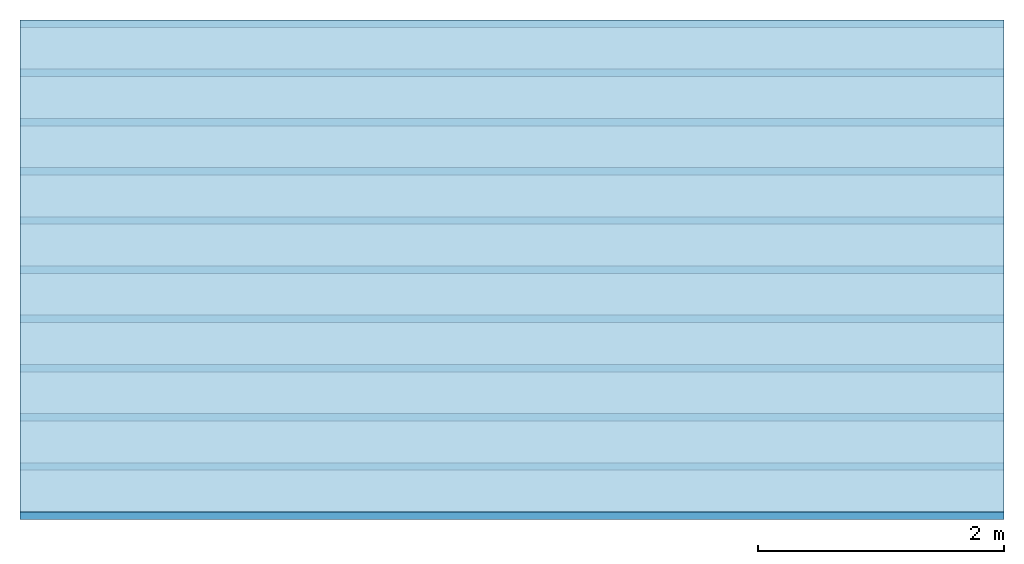
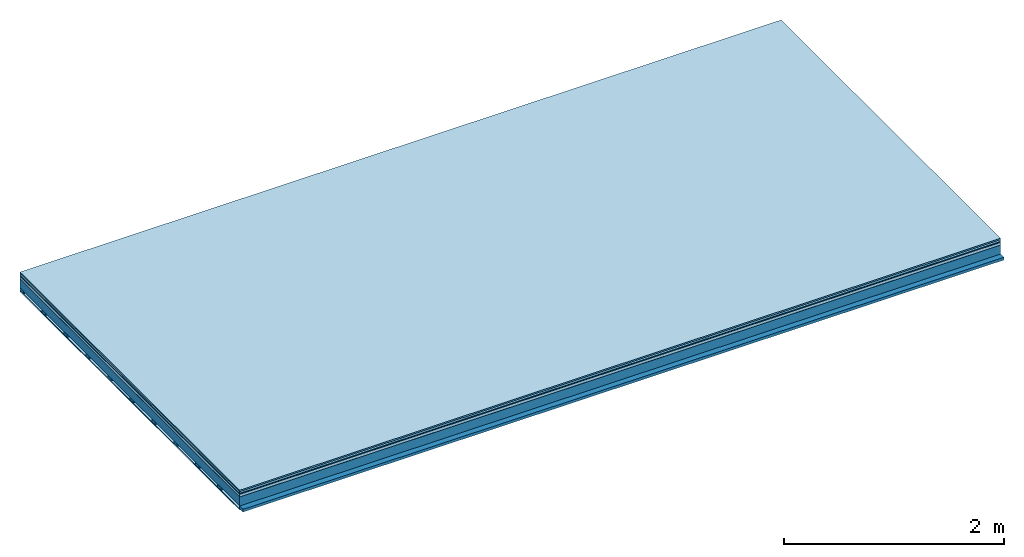
# One storey: 7 plates, 2 members, 1 element without a shape of its own.
"""IFC4 building model written with IfcOpenShell, lengths in metres."""

import ifcopenshell
import ifcopenshell.guid

model = None  # the IFC model being written
_history = None  # IfcOwnerHistory: only IFC2X3 demands one
_inside = {}  # id of a spatial element -> (the spatial element, [elements in it])
_under = {}  # id of a project, library or spatial element -> (it, [spatial elements below it])
_declared = {}  # id of a project -> (the project, [libraries it declares])
_typed = {}  # id of a type object -> (the type object, [elements of that type])
_made_of = {}  # id of a material, layer set ... -> (it, [elements and type objects made of it])


def new_model(schema):
    """Start an empty IFC model of exactly this schema.

    Asked for "IFC4X3", IfcOpenShell would pick the latest addendum, in which some entities
    have other attributes; the version numbers below select the first issue.
    IFC2X3 requires an IfcOwnerHistory on every rooted entity: one is made here for all.
    """
    global model, _history
    if schema == "IFC4X3":
        model = ifcopenshell.file(schema_version=(4, 3, 0, 0))
    else:
        model = ifcopenshell.file(schema=schema)
    _inside.clear()
    _under.clear()
    _declared.clear()
    _typed.clear()
    _made_of.clear()
    _history = None
    if model.schema == "IFC2X3":
        org = make("IfcOrganization", Name="unknown")
        user = make(
            "IfcPersonAndOrganization",
            ThePerson=make("IfcPerson", FamilyName="unknown"),
            TheOrganization=org,
        )
        app = make(
            "IfcApplication",
            ApplicationDeveloper=org,
            Version="unknown",
            ApplicationFullName="unknown",
            ApplicationIdentifier="unknown",
        )
        _history = make(
            "IfcOwnerHistory",
            OwningUser=user,
            OwningApplication=app,
            ChangeAction="ADDED",
            CreationDate=0,
        )
    return model


def make(cls, **values):
    """One entity of the class cls with the attributes given. An attribute that is None is left unset."""
    return model.create_entity(
        cls, **{name: value for name, value in values.items() if value is not None}
    )


def rooted(cls, **values):
    """An entity with a GlobalId (a new one), such as an element, a storey or a relation."""
    return make(cls, GlobalId=ifcopenshell.guid.new(), OwnerHistory=_history, **values)


def si_unit(unit_type, name, prefix=None):
    """IfcSIUnit, for example si_unit("LENGTHUNIT", "METRE", prefix="MILLI")."""
    return make("IfcSIUnit", UnitType=unit_type, Prefix=prefix, Name=name)


def derived_unit(unit_type, elements):
    """IfcDerivedUnit: a product of units, each with its exponent."""
    return make(
        "IfcDerivedUnit",
        Elements=[
            make("IfcDerivedUnitElement", Unit=unit, Exponent=power)
            for unit, power in elements
        ],
        UnitType=unit_type,
    )


def assignment(units):
    """IfcUnitAssignment: the units of a project."""
    return None if units is None else make("IfcUnitAssignment", Units=units)


def point(xyz):
    """IfcCartesianPoint."""
    return None if xyz is None else make("IfcCartesianPoint", Coordinates=xyz)


def direction(xyz):
    """IfcDirection."""
    return None if xyz is None else make("IfcDirection", DirectionRatios=xyz)


def frame(location, z_axis=None, x_axis=None):
    """IfcAxis2Placement3D, a coordinate frame: its origin and axes. An axis left out is left unset."""
    return make(
        "IfcAxis2Placement3D",
        Location=point(location),
        Axis=direction(z_axis),
        RefDirection=direction(x_axis),
    )


def frame_2d(location, x_axis=None):
    """IfcAxis2Placement2D, a coordinate frame in the plane: its origin and x axis."""
    return make(
        "IfcAxis2Placement2D", Location=point(location), RefDirection=direction(x_axis)
    )


def origin():
    """The frame at (0, 0, 0) with its axes left unset."""
    return frame((0.0, 0.0, 0.0))


def origin_with_axes():
    """The frame at (0, 0, 0) with the z axis (0, 0, 1) and the x axis (1, 0, 0) written out."""
    return frame((0.0, 0.0, 0.0), z_axis=(0.0, 0.0, 1.0), x_axis=(1.0, 0.0, 0.0))


def place(relative_to, where):
    """IfcLocalPlacement: puts the frame where relative to a parent placement (None: the world)."""
    return make(
        "IfcLocalPlacement", PlacementRelTo=relative_to, RelativePlacement=where
    )


def context(
    kind, dimensions, precision=None, world=None, true_north=None, identifier=None
):
    """IfcGeometricRepresentationContext, for example the 3D "Model" context."""
    return make(
        "IfcGeometricRepresentationContext",
        ContextIdentifier=identifier,
        ContextType=kind,
        CoordinateSpaceDimension=dimensions,
        Precision=precision,
        WorldCoordinateSystem=world,
        TrueNorth=true_north,
    )


def project(units=None, contexts=None):
    """IfcProject with its units and contexts."""
    return rooted(
        "IfcProject",
        Name="project",
        RepresentationContexts=contexts,
        UnitsInContext=assignment(units),
    )


def spatial(cls, under=None, at=None, **own):
    """A site, building, storey or space (cls), placed at a placement, below another one or the project."""
    s = rooted(cls, ObjectPlacement=at, **own)
    if under is not None:
        _under.setdefault(under.id(), (under, []))[1].append(s)
    return s


def profile(cls, at=None, kind="AREA", **sizes):
    """A parametric profile (cls). Its sizes go by their IFC names, for example OverallWidth=200.0."""
    return make(cls, ProfileType=kind, Position=at, **sizes)


def rectangle(**sizes):
    """IfcRectangleProfileDef."""
    return profile("IfcRectangleProfileDef", **sizes)


def extrude(swept, where, along, depth):
    """IfcExtrudedAreaSolid: the profile swept, set in the frame where, extruded along a direction by depth."""
    return make(
        "IfcExtrudedAreaSolid",
        SweptArea=swept,
        Position=where,
        ExtrudedDirection=direction(along),
        Depth=depth,
    )


def shape(context_of_items, identifier, shape_type, items):
    """IfcShapeRepresentation: the items that make up one representation, for example the "Body"."""
    return make(
        "IfcShapeRepresentation",
        ContextOfItems=context_of_items,
        RepresentationIdentifier=identifier,
        RepresentationType=shape_type,
        Items=items,
    )


def material(Name=None, Category=None):
    """IfcMaterial."""
    return make("IfcMaterial", Name=Name, Category=Category)


def layer(
    of_material, thickness, ventilated=None, Name=None, Category=None, Priority=None
):
    """IfcMaterialLayer: one layer of a wall or slab, of a material (None: an air gap)."""
    return make(
        "IfcMaterialLayer",
        Material=of_material,
        LayerThickness=thickness,
        IsVentilated=ventilated,
        Name=Name,
        Category=Category,
        Priority=Priority,
    )


def layer_set(layers, Name=None):
    """IfcMaterialLayerSet."""
    return make("IfcMaterialLayerSet", MaterialLayers=layers, LayerSetName=Name)


def made_of(thing, what):
    """Note that an element or type object is made of a material, layer set ...; save() writes the relation."""
    if what is not None:
        _made_of.setdefault(what.id(), (what, []))[1].append(thing)
    return thing


def type_object(cls, material=None, **own):
    """A type object (cls), such as IfcWallType, which elements share."""
    return made_of(rooted(cls, **own), material)


def element(
    cls,
    number,
    at=None,
    inside=None,
    cuts=None,
    type_object=None,
    material=None,
    context=None,
    identifier="Body",
    shape_type=None,
    held_by="IfcProductDefinitionShape",
    body=None,
    shapes=None,
    **own,
):
    """One element of the class cls, such as IfcWall. Its Tag is "e" and its number.

    at: its placement. inside: the storey or other place that contains it. cuts: it is an
    opening in that element (IfcRelVoidsElement). A single representation is given by context,
    identifier, shape_type and body (its items); several are given by shapes. held_by: the class
    of the entity that holds the representations. save() writes the other relations.
    """
    e = rooted(cls, Tag="e%d" % number, ObjectPlacement=at, **own)
    if body is not None:
        shapes = [shape(context, identifier, shape_type, body)]
    if shapes is not None:
        e.Representation = make(held_by, Representations=shapes)
    if inside is not None:
        _inside.setdefault(inside.id(), (inside, []))[1].append(e)
    if cuts is not None:
        rooted(
            "IfcRelVoidsElement", RelatingBuildingElement=cuts, RelatedOpeningElement=e
        )
    if type_object is not None:
        _typed.setdefault(type_object.id(), (type_object, []))[1].append(e)
    return made_of(e, material)


def aggregate(whole, parts):
    """IfcRelAggregates: a whole, such as a stair, and the parts it consists of."""
    return rooted("IfcRelAggregates", RelatingObject=whole, RelatedObjects=parts)


def save(model, path):
    """Write the relations noted so far, then the file.

    IfcRelAggregates (storeys below a building ...), IfcRelContainedInSpatialStructure (elements
    in a storey), IfcRelDefinesByType, IfcRelAssociatesMaterial and IfcRelDeclares: one each for
    every whole, place, type object, material and project.
    """
    for whole, parts in _under.values():
        aggregate(whole, parts)
    for where, things in _inside.values():
        rooted(
            "IfcRelContainedInSpatialStructure",
            RelatedElements=things,
            RelatingStructure=where,
        )
    for kind, things in _typed.values():
        rooted("IfcRelDefinesByType", RelatedObjects=things, RelatingType=kind)
    for what, things in _made_of.values():
        rooted("IfcRelAssociatesMaterial", RelatedObjects=things, RelatingMaterial=what)
    for by, libraries in _declared.values():
        rooted("IfcRelDeclares", RelatingContext=by, RelatedDefinitions=libraries)
    model.write(path)


model = new_model("IFC4")

# Units and contexts
plan_context = context("Plan", 3, precision=1e-05, world=origin(), true_north=direction((0.0, 1.0)))
model_context = context("Model", 3, precision=1e-05, world=origin(), true_north=direction((0.0, 1.0)))
ifc_project = project(units=[si_unit("LENGTHUNIT", "METRE"), derived_unit("SOUNDPRESSUREUNIT", [(si_unit("PRESSUREUNIT", "PASCAL", prefix="MICRO"), 0)]), si_unit("ENERGYUNIT", "JOULE", prefix="MEGA"), si_unit("MASSUNIT", "GRAM", prefix="KILO"), derived_unit("THERMALTRANSMITTANCEUNIT", [(si_unit("POWERUNIT", "WATT"), 1), (si_unit("AREAUNIT", "SQUARE_METRE"), -1), (si_unit("THERMODYNAMICTEMPERATUREUNIT", "KELVIN"), -1)]), derived_unit("AREADENSITYUNIT", [(si_unit("MASSUNIT", "GRAM", prefix="KILO"), 1), (si_unit("AREAUNIT", "SQUARE_METRE"), -1)]), derived_unit("USERDEFINED", [(si_unit("ENERGYUNIT", "JOULE", prefix="MEGA"), 1), (si_unit("AREAUNIT", "SQUARE_METRE"), -1)])], contexts=[plan_context, model_context])

# Site, building, storey
site = spatial("IfcSite", under=ifc_project)
building_placement = place(None, origin())
building = spatial("IfcBuilding", under=site, at=building_placement)
storey_placement = place(building_placement, origin())
storey = spatial("IfcBuildingStorey", under=building, at=storey_placement)

# Slab, members, plates
ifc_material_1 = material(Category="11.013")
ifc_layer_1 = layer(ifc_material_1, 0.015, Name="Flooring")
ifc_material_2 = material(Category="03.007")
ifc_layer_2 = layer(ifc_material_2, 0.02, Name="On-material")
ifc_material_3 = material(Name="Wood fiber generic product", Category="10.009")
ifc_layer_3 = layer(ifc_material_3, 0.01, Name="Impact sound insulation")
ifc_material_4 = material(Name="with broken")
ifc_layer_4 = layer(ifc_material_4, 0.03, Name="on Supporting structure")
ifc_material_5 = material(Name="protection", Category="09.007")
ifc_layer_5 = layer(ifc_material_5, 0.0005, Name="Sub-floor")
ifc_material_6 = material(Name="no composite action")
ifc_layer_6 = layer(ifc_material_6, 0.0, Name="Bond")
ifc_layer_7 = layer(None, 0.1, Name="Supporting structure")
ifc_material_7 = material(Name="of the art")
ifc_layer_8 = layer(ifc_material_7, 0.0, Name="Bond")
ifc_layer_9 = layer(None, 0.03, Name="Battens / profiles")
ifc_material_8 = material(Name="Plasterboard type A", Category="03.008")
ifc_layer_10 = layer(ifc_material_8, 0.0125, Name="Ceiling covering 1st layer")
ifc_material_9 = material(Category="04.001")
ifc_layer_11 = layer(ifc_material_9, 0.003, Name="Surface / treatment")
ifc_layer_set = layer_set([ifc_layer_1, ifc_layer_2, ifc_layer_3, ifc_layer_4, ifc_layer_5, ifc_layer_6, ifc_layer_7, ifc_layer_8, ifc_layer_9, ifc_layer_10, ifc_layer_11])
slab_type = type_object("IfcSlabType", Name="A2104", PredefinedType="NOTDEFINED", material=ifc_layer_set)
slab_placement = place(None, frame((0.0, 0.0, 0.0), z_axis=(0.0, 0.0, -1.0), x_axis=(1.0, 0.0, 0.0)))
slab = element("IfcSlab", 1, at=slab_placement, inside=storey, type_object=slab_type, material=ifc_layer_set, Name="Slab #1")
ifc_material_10 = material(Name="Solid timber panel")
member_1_placement = place(slab_placement, origin())
member_1 = element("IfcMember", 2, at=member_1_placement, material=ifc_material_10, Name="Supporting structure", context=plan_context, shape_type="SweptSolid", body=[
    extrude(rectangle(XDim=1.0, YDim=0.1, at=frame_2d((0.5, 0.05), x_axis=(1.0, 0.0))), frame((0.0, 4.0, 0.0755), z_axis=(0.0, -1.0, 0.0), x_axis=(1.0, 0.0, 0.0)), (0.0, 0.0, 1.0), 4.0),
    extrude(rectangle(XDim=1.0, YDim=0.1, at=frame_2d((0.5, 0.05), x_axis=(1.0, 0.0))), frame((1.0, 4.0, 0.0755), z_axis=(0.0, -1.0, 0.0), x_axis=(1.0, 0.0, 0.0)), (0.0, 0.0, 1.0), 4.0),
    extrude(rectangle(XDim=1.0, YDim=0.1, at=frame_2d((0.5, 0.05), x_axis=(1.0, 0.0))), frame((2.0, 4.0, 0.0755), z_axis=(0.0, -1.0, 0.0), x_axis=(1.0, 0.0, 0.0)), (0.0, 0.0, 1.0), 4.0),
    extrude(rectangle(XDim=1.0, YDim=0.1, at=frame_2d((0.5, 0.05), x_axis=(1.0, 0.0))), frame((3.0, 4.0, 0.0755), z_axis=(0.0, -1.0, 0.0), x_axis=(1.0, 0.0, 0.0)), (0.0, 0.0, 1.0), 4.0),
    extrude(rectangle(XDim=1.0, YDim=0.1, at=frame_2d((0.5, 0.05), x_axis=(1.0, 0.0))), frame((4.0, 4.0, 0.0755), z_axis=(0.0, -1.0, 0.0), x_axis=(1.0, 0.0, 0.0)), (0.0, 0.0, 1.0), 4.0),
    extrude(rectangle(XDim=1.0, YDim=0.1, at=frame_2d((0.5, 0.05), x_axis=(1.0, 0.0))), frame((5.0, 4.0, 0.0755), z_axis=(0.0, -1.0, 0.0), x_axis=(1.0, 0.0, 0.0)), (0.0, 0.0, 1.0), 4.0),
    extrude(rectangle(XDim=1.0, YDim=0.1, at=frame_2d((0.5, 0.05), x_axis=(1.0, 0.0))), frame((6.0, 4.0, 0.0755), z_axis=(0.0, -1.0, 0.0), x_axis=(1.0, 0.0, 0.0)), (0.0, 0.0, 1.0), 4.0),
    extrude(rectangle(XDim=1.0, YDim=0.1, at=frame_2d((0.5, 0.05), x_axis=(1.0, 0.0))), frame((7.0, 4.0, 0.0755), z_axis=(0.0, -1.0, 0.0), x_axis=(1.0, 0.0, 0.0)), (0.0, 0.0, 1.0), 4.0),
])
ifc_material_11 = material()
member_2_placement = place(slab_placement, origin())
member_2 = element("IfcMember", 3, at=member_2_placement, material=ifc_material_11, Name="Battens / profiles", context=plan_context, shape_type="SweptSolid", body=[
    extrude(rectangle(XDim=0.06, YDim=0.03, at=frame_2d((0.03, 0.015), x_axis=(1.0, 0.0))), frame((0.0, 0.0, 0.1755), z_axis=(1.0, 0.0, 0.0), x_axis=(0.0, 1.0, 0.0)), (0.0, 0.0, 1.0), 8.0),
    extrude(rectangle(XDim=0.06, YDim=0.03, at=frame_2d((0.03, 0.015), x_axis=(1.0, 0.0))), frame((0.0, 0.4, 0.1755), z_axis=(1.0, 0.0, 0.0), x_axis=(0.0, 1.0, 0.0)), (0.0, 0.0, 1.0), 8.0),
    extrude(rectangle(XDim=0.06, YDim=0.03, at=frame_2d((0.03, 0.015), x_axis=(1.0, 0.0))), frame((0.0, 0.8, 0.1755), z_axis=(1.0, 0.0, 0.0), x_axis=(0.0, 1.0, 0.0)), (0.0, 0.0, 1.0), 8.0),
    extrude(rectangle(XDim=0.06, YDim=0.03, at=frame_2d((0.03, 0.015), x_axis=(1.0, 0.0))), frame((0.0, 1.2, 0.1755), z_axis=(1.0, 0.0, 0.0), x_axis=(0.0, 1.0, 0.0)), (0.0, 0.0, 1.0), 8.0),
    extrude(rectangle(XDim=0.06, YDim=0.03, at=frame_2d((0.03, 0.015), x_axis=(1.0, 0.0))), frame((0.0, 1.6, 0.1755), z_axis=(1.0, 0.0, 0.0), x_axis=(0.0, 1.0, 0.0)), (0.0, 0.0, 1.0), 8.0),
    extrude(rectangle(XDim=0.06, YDim=0.03, at=frame_2d((0.03, 0.015), x_axis=(1.0, 0.0))), frame((0.0, 2.0, 0.1755), z_axis=(1.0, 0.0, 0.0), x_axis=(0.0, 1.0, 0.0)), (0.0, 0.0, 1.0), 8.0),
    extrude(rectangle(XDim=0.06, YDim=0.03, at=frame_2d((0.03, 0.015), x_axis=(1.0, 0.0))), frame((0.0, 2.4, 0.1755), z_axis=(1.0, 0.0, 0.0), x_axis=(0.0, 1.0, 0.0)), (0.0, 0.0, 1.0), 8.0),
    extrude(rectangle(XDim=0.06, YDim=0.03, at=frame_2d((0.03, 0.015), x_axis=(1.0, 0.0))), frame((0.0, 2.8, 0.1755), z_axis=(1.0, 0.0, 0.0), x_axis=(0.0, 1.0, 0.0)), (0.0, 0.0, 1.0), 8.0),
    extrude(rectangle(XDim=0.06, YDim=0.03, at=frame_2d((0.03, 0.015), x_axis=(1.0, 0.0))), frame((0.0, 3.2, 0.1755), z_axis=(1.0, 0.0, 0.0), x_axis=(0.0, 1.0, 0.0)), (0.0, 0.0, 1.0), 8.0),
    extrude(rectangle(XDim=0.06, YDim=0.03, at=frame_2d((0.03, 0.015), x_axis=(1.0, 0.0))), frame((0.0, 3.6, 0.1755), z_axis=(1.0, 0.0, 0.0), x_axis=(0.0, 1.0, 0.0)), (0.0, 0.0, 1.0), 8.0),
    extrude(rectangle(XDim=0.06, YDim=0.03, at=frame_2d((0.03, 0.015), x_axis=(1.0, 0.0))), frame((0.0, 4.0, 0.1755), z_axis=(1.0, 0.0, 0.0), x_axis=(0.0, 1.0, 0.0)), (0.0, 0.0, 1.0), 8.0),
])
plate_1_placement = place(slab_placement, origin())
plate_1 = element("IfcPlate", 4, at=plate_1_placement, material=ifc_material_1, Name="Flooring", context=plan_context, shape_type="SweptSolid", body=[
    extrude(rectangle(XDim=8.0, YDim=4.0, at=frame_2d((4.0, 2.0), x_axis=(1.0, 0.0))), origin_with_axes(), (0.0, 0.0, 1.0), 0.015),
])
plate_2_placement = place(slab_placement, origin())
plate_2 = element("IfcPlate", 5, at=plate_2_placement, material=ifc_material_2, Name="On-material", context=plan_context, shape_type="SweptSolid", body=[
    extrude(rectangle(XDim=8.0, YDim=4.0, at=frame_2d((4.0, 2.0), x_axis=(1.0, 0.0))), frame((0.0, 0.0, 0.015), z_axis=(0.0, 0.0, 1.0), x_axis=(1.0, 0.0, 0.0)), (0.0, 0.0, 1.0), 0.02),
])
plate_3_placement = place(slab_placement, origin())
plate_3 = element("IfcPlate", 6, at=plate_3_placement, material=ifc_material_3, Name="Impact sound insulation", context=plan_context, shape_type="SweptSolid", body=[
    extrude(rectangle(XDim=8.0, YDim=4.0, at=frame_2d((4.0, 2.0), x_axis=(1.0, 0.0))), frame((0.0, 0.0, 0.035), z_axis=(0.0, 0.0, 1.0), x_axis=(1.0, 0.0, 0.0)), (0.0, 0.0, 1.0), 0.01),
])
plate_4_placement = place(slab_placement, origin())
plate_4 = element("IfcPlate", 7, at=plate_4_placement, material=ifc_material_4, Name="on Supporting structure", context=plan_context, shape_type="SweptSolid", body=[
    extrude(rectangle(XDim=8.0, YDim=4.0, at=frame_2d((4.0, 2.0), x_axis=(1.0, 0.0))), frame((0.0, 0.0, 0.045), z_axis=(0.0, 0.0, 1.0), x_axis=(1.0, 0.0, 0.0)), (0.0, 0.0, 1.0), 0.03),
])
plate_5_placement = place(slab_placement, origin())
plate_5 = element("IfcPlate", 8, at=plate_5_placement, material=ifc_material_5, Name="Sub-floor", context=plan_context, shape_type="SweptSolid", body=[
    extrude(rectangle(XDim=8.0, YDim=4.0, at=frame_2d((4.0, 2.0), x_axis=(1.0, 0.0))), frame((0.0, 0.0, 0.075), z_axis=(0.0, 0.0, 1.0), x_axis=(1.0, 0.0, 0.0)), (0.0, 0.0, 1.0), 0.0005),
])
plate_6_placement = place(slab_placement, origin())
plate_6 = element("IfcPlate", 9, at=plate_6_placement, material=ifc_material_8, Name="Ceiling covering 1st layer", context=plan_context, shape_type="SweptSolid", body=[
    extrude(rectangle(XDim=8.0, YDim=4.0, at=frame_2d((4.0, 2.0), x_axis=(1.0, 0.0))), frame((0.0, 0.0, 0.2055), z_axis=(0.0, 0.0, 1.0), x_axis=(1.0, 0.0, 0.0)), (0.0, 0.0, 1.0), 0.0125),
])
plate_7_placement = place(slab_placement, origin())
plate_7 = element("IfcPlate", 10, at=plate_7_placement, material=ifc_material_9, Name="Surface / treatment", context=plan_context, shape_type="SweptSolid", body=[
    extrude(rectangle(XDim=8.0, YDim=4.0, at=frame_2d((4.0, 2.0), x_axis=(1.0, 0.0))), frame((0.0, 0.0, 0.218), z_axis=(0.0, 0.0, 1.0), x_axis=(1.0, 0.0, 0.0)), (0.0, 0.0, 1.0), 0.003),
])
aggregate(slab, [plate_1, plate_2, plate_3, plate_4, plate_5, member_1, member_2, plate_6, plate_7])

save(model, "model.ifc")
